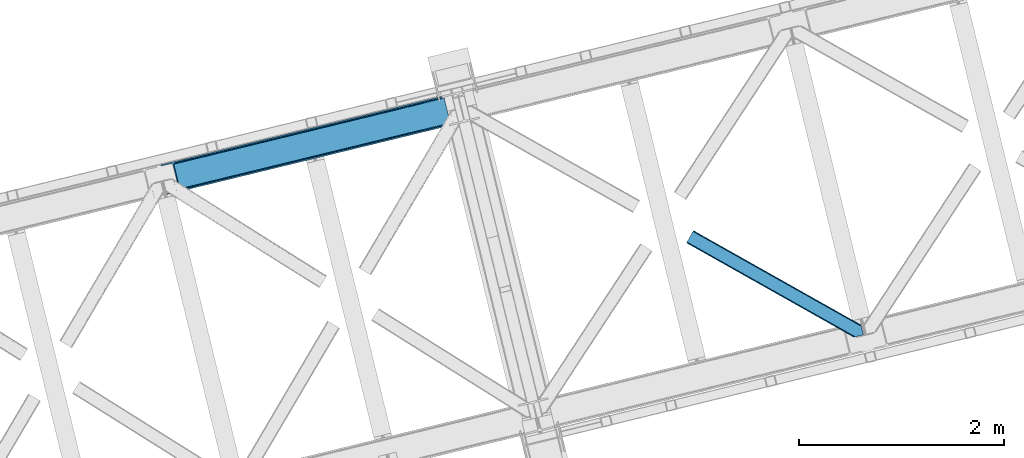
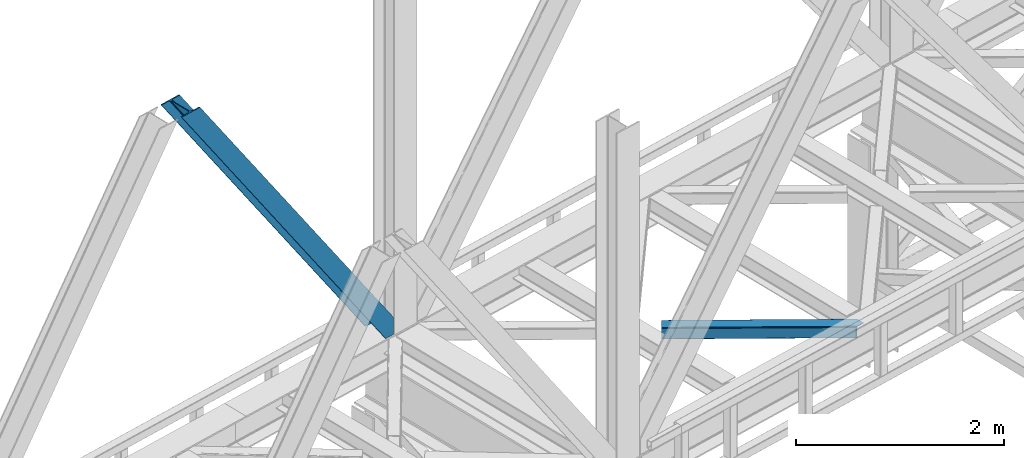
# One storey, part 38 of 93: 2 members.
"""IFC4 building model written with IfcOpenShell, lengths in millimetres."""

from ifc_helpers import new_model, entity, si_unit, converted_unit, derived_unit, direction, frame, origin, place, context, subcontext, project, spatial, triangles, type_object, element, save


model = new_model("IFC4")

# Units and contexts
model_context = context("Model", 3, precision=0.01, world=origin(), true_north=direction((6.12303176911189e-17, 1.0)))
plan_context = context("Plan", 3, precision=0.01, world=origin(), true_north=direction((6.12303176911189e-17, 1.0)))
body_context = subcontext(model_context, "Body", "Model", "MODEL_VIEW")
ifc_project = project(units=[si_unit("LENGTHUNIT", "METRE", prefix="MILLI"), si_unit("AREAUNIT", "SQUARE_METRE"), si_unit("VOLUMEUNIT", "CUBIC_METRE"), converted_unit("PLANEANGLEUNIT", "DEGREE", entity("IfcRatioMeasure", 0.0174532925199433), si_unit("PLANEANGLEUNIT", "RADIAN"), dimensions=[0, 0, 0, 0, 0, 0, 0]), si_unit("MASSUNIT", "GRAM", prefix="KILO"), derived_unit("MASSDENSITYUNIT", [(si_unit("MASSUNIT", "GRAM", prefix="KILO"), 1), (si_unit("LENGTHUNIT", "METRE"), -3)]), derived_unit("MOMENTOFINERTIAUNIT", [(si_unit("LENGTHUNIT", "METRE"), 4)]), si_unit("TIMEUNIT", "SECOND"), si_unit("FREQUENCYUNIT", "HERTZ"), si_unit("THERMODYNAMICTEMPERATUREUNIT", "DEGREE_CELSIUS"), derived_unit("THERMALTRANSMITTANCEUNIT", [(si_unit("MASSUNIT", "GRAM", prefix="KILO"), 1), (si_unit("THERMODYNAMICTEMPERATUREUNIT", "KELVIN"), -1), (si_unit("TIMEUNIT", "SECOND"), -3)]), derived_unit("VOLUMETRICFLOWRATEUNIT", [(si_unit("LENGTHUNIT", "METRE"), 3), (si_unit("TIMEUNIT", "SECOND"), -1)]), derived_unit("MASSFLOWRATEUNIT", [(si_unit("MASSUNIT", "GRAM", prefix="KILO"), 1), (si_unit("TIMEUNIT", "SECOND"), -1)]), derived_unit("ROTATIONALFREQUENCYUNIT", [(si_unit("TIMEUNIT", "SECOND"), -1)]), si_unit("ELECTRICCURRENTUNIT", "AMPERE"), si_unit("ELECTRICVOLTAGEUNIT", "VOLT"), si_unit("POWERUNIT", "WATT"), si_unit("FORCEUNIT", "NEWTON", prefix="KILO"), si_unit("ILLUMINANCEUNIT", "LUX"), si_unit("LUMINOUSFLUXUNIT", "LUMEN"), si_unit("LUMINOUSINTENSITYUNIT", "CANDELA"), derived_unit("USERDEFINED", [(si_unit("MASSUNIT", "GRAM", prefix="KILO"), -1), (si_unit("LENGTHUNIT", "METRE"), -2), (si_unit("TIMEUNIT", "SECOND"), 3), (si_unit("LUMINOUSFLUXUNIT", "LUMEN"), 1)]), derived_unit("LINEARVELOCITYUNIT", [(si_unit("LENGTHUNIT", "METRE"), 1), (si_unit("TIMEUNIT", "SECOND"), -1)]), si_unit("PRESSUREUNIT", "PASCAL"), derived_unit("USERDEFINED", [(si_unit("LENGTHUNIT", "METRE"), -2), (si_unit("MASSUNIT", "GRAM", prefix="KILO"), 1), (si_unit("TIMEUNIT", "SECOND"), -2)]), derived_unit("LINEARFORCEUNIT", [(si_unit("MASSUNIT", "GRAM", prefix="KILO"), 1), (si_unit("LENGTHUNIT", "METRE"), 1), (si_unit("TIMEUNIT", "SECOND"), -2), (si_unit("LENGTHUNIT", "METRE"), -1)]), derived_unit("PLANARFORCEUNIT", [(si_unit("MASSUNIT", "GRAM", prefix="KILO"), 1), (si_unit("LENGTHUNIT", "METRE"), 1), (si_unit("TIMEUNIT", "SECOND"), -2), (si_unit("LENGTHUNIT", "METRE"), -2)])], contexts=[model_context, plan_context])

# Site, building, storey
site_placement = place(None, origin())
site = spatial("IfcSite", under=ifc_project, at=site_placement, CompositionType="ELEMENT")
building_placement = place(site_placement, origin())
building = spatial("IfcBuilding", under=site, at=building_placement, CompositionType="ELEMENT")
storey_placement = place(building_placement, frame((0.0, 0.0, 15900.0)))
storey = spatial("IfcBuildingStorey", under=building, at=storey_placement, CompositionType="ELEMENT", Elevation=15900.0)

# Members
member_type_1 = type_object("IfcMemberType", PredefinedType="BRACE")
member_1_placement = place(storey_placement, frame((-52278.8368652344, 7914.03961029053, 3694.99929199219)))
element("IfcMember", 1, at=member_1_placement, inside=storey, type_object=member_type_1, ObjectType="Steel Vertical Brace", PredefinedType="BRACE", context=body_context, shape_type="Tessellation", body=[
    triangles([(2824.17180175782, 696.209248352051, 0.781347656247817), (2824.8368774414, 695.227912902831, 1.0697021484375), (2823.33929443359, 694.862818908691, 0.0), (2821.44638671875, 702.635018920898, 0.0), (2812.38182373047, 692.19088897705, 19.5569458007813), (2812.38182373047, 692.19088897705, 0.0), (2386.756640625, 583.574263000489, 658.75048828125), (2392.34234619141, 580.919773864746, 662.07819213867), (2803.98698730469, 681.26248626709, 51.2480346679658), (2804.11721191406, 683.186787414551, 44.4996093749978), (2382.25924072265, 588.488497924805, 656.525042724606), (2808.48903808594, 690.380534362793, 26.4030395507798), (2805.01948242188, 685.664543151855, 38.2720825195283), (2805.58688964844, 687.218518066406, 34.3676696777329), (630.519653320313, 150.046073913574, 3288.98063964843), (624.696752929689, 150.036772155761, 3285.05529785156), (211.3359375, 47.8656829833981, 3911.00081176758), (202.866687011723, 47.2110717773439, 3911.00081176758), (619.11104736328, 152.691842651367, 3281.72759399414), (195.039257812503, 49.3190826416012, 3911.00081176758), (614.613647460938, 157.60549621582, 3279.50447387695), (189.03962402344, 53.868223571777, 3911.00081176758), (611.888232421879, 164.031266784667, 3278.7231262207), (185.788659667967, 60.1655136108393, 3911.00081176758), (2804.10791015625, 679.881175231933, 63.6403015136711), (2398.16524658203, 580.929075622559, 666.003533935545), (1956.25733642578, 473.208325195313, 1321.74955444336), (1950.42978515625, 473.1990234375, 1317.82188720703), (1508.521875, 365.478273010253, 1973.56790771484), (1514.34477539063, 365.487574768066, 1977.49324951172), (1066.60931396484, 257.757522583008, 2629.3116027832), (1072.43221435547, 257.76682434082, 2633.23694458008), (1944.84873046875, 475.854093933106, 1314.49418334961), (1502.93151855469, 368.132762145996, 1970.23787841797), (1061.02360839844, 260.412011718749, 2625.98389892578), (1940.3466796875, 480.767747497558, 1312.27106323242), (1498.43411865235, 373.046997070312, 1968.01475830078), (1056.52620849609, 265.326246643066, 2623.75845336914), (2379.5338256836, 594.914268493651, 655.74602050781), (1937.62126464844, 487.193518066407, 1311.48971557617), (1495.71335449219, 379.47276763916, 1967.23341064453), (1053.80079345703, 271.752017211914, 2622.97710571289), (2766.268359375, 929.006666564942, 0.0), (2324.35579833984, 821.285916137695, 655.74602050781), (1882.44323730469, 713.565165710449, 1311.48971557617), (1440.53067626953, 605.844415283203, 1967.23341064453), (998.618115234378, 498.123664855956, 2622.97710571289), (556.705554199223, 390.402914428711, 3278.7231262207), (130.61063232422, 286.537161254883, 3911.00081176758), (303.26520996094, 70.2747802734375, 3911.00081176758), (2804.10791015625, 679.881175231933, 200.055230712889), (2807.14028320312, 667.240086364746, 200.120343017577), (2804.29859619141, 678.898677062988, 200.120343017577), (306.344091796876, 57.6447372436523, 3911.00081176758), (2807.14028320312, 667.240086364746, 0.0), (2804.29859619141, 678.898677062988, 0.0), (2804.0009399414, 682.093249511719, 0.0), (2804.11721191406, 683.186787414551, 2.42078247070094), (2804.72182617187, 685.456997680664, 5.12991943359157), (2805.58688964844, 687.218518066406, 5.67639770507594), (2807.01936035157, 689.087008666992, 4.89505004882813), (2808.48903808594, 690.380534362793, 3.35328369140552), (2811.04237060547, 691.772309875488, 0.0), (2705.52322998047, 642.470086669921, 0.0), (69.865502929686, 0.0, 3911.00081176758), (2794.37827148438, 677.509226989746, 0.0), (2802.00106201172, 681.140400695801, 0.0), (2702.44434814453, 655.100129699706, 0.0), (66.78662109375, 12.6306243896479, 3911.00081176758), (1480.00268554688, 357.117155456544, 1950.37164916992), (1034.29035644532, 248.469717407226, 2611.75686035156), (588.578027343749, 139.82227935791, 3273.1420715332), (158.720544433592, 35.0397216796873, 3911.00081176758), (1925.71966552734, 465.76459350586, 1288.98643798828), (2371.43199462891, 574.412031555176, 627.598901367186), (2376.60842285156, 577.083380126954, 631.526568603513), (2380.34307861328, 582.010986328124, 634.854272460936), (2381.53835449219, 595.402610778808, 637.858740234373), (2811.39583740234, 700.185168457031, 0.0), (2811.09818115235, 693.083857727051, 0.0), (2382.07785644531, 588.443733215331, 637.077392578125), (598.684387207031, 160.812858581543, 3283.40191040039), (599.21923828125, 153.853981018066, 3282.62056274414), (175.738110351565, 57.7156631469725, 3911.00081176758), (175.752062988286, 50.6283050537104, 3911.00081176758), (597.489111328126, 147.421234130859, 3280.39744262695), (172.519702148442, 43.8304641723635, 3911.00081176758), (593.749804687504, 142.493627929687, 3277.06973876953), (166.538671875001, 38.3563796997068, 3911.00081176758), (1936.36087646485, 479.796295166015, 1298.46260375976), (1935.82602539063, 486.755172729491, 1299.24395141601), (1490.64854736329, 371.148857116698, 1959.85014038086), (1490.10904541016, 378.107734680175, 1960.63148803711), (1044.3967163086, 269.460296630859, 2622.01669921875), (1044.93621826172, 262.501419067383, 2621.2353515625), (1934.63074951172, 473.363548278808, 1296.23948364258), (1488.91376953125, 364.716110229491, 1957.62469482422), (1043.20144042969, 256.068672180176, 2619.01223144531), (1930.89144287109, 468.435942077637, 1292.91177978515), (1485.17911376953, 359.788504028321, 1954.2969909668), (1039.46678466797, 251.141065979004, 2615.68220214844), (2756.2178100586, 926.556816101073, 0.0), (2326.36032714844, 821.774258422852, 637.858740234373), (1434.93101806641, 604.479382324219, 1960.63148803711), (1880.64334716797, 713.126820373535, 1299.24395141601), (989.214038085942, 495.831944274903, 2622.01669921875), (543.501708984375, 387.184506225586, 3283.40191040039), (120.560083007811, 284.087310791015, 3911.00081176758), (2752.68314208985, 932.723881530762, 0.0), (2753.40867919922, 934.106936645508, 0.0), (2752.03201904297, 933.86276550293, 0.0), (2764.37080078125, 936.778866577149, 0.0), (2753.40867919922, 934.106936645508, 19.5569458007813), (2765.86838378906, 937.143960571289, 1.0697021484375), (2765.72885742188, 935.96612548828, 0.781347656247817), (2325.55107421875, 834.677540588379, 658.75048828125), (2749.12521972656, 933.923808288574, 26.4030395507798), (2745.08825683594, 935.395230102539, 34.3676696777329), (2323.81629638672, 828.244793701172, 656.525042724606), (2743.51160888672, 936.560275268555, 38.5441589355469), (556.170703125004, 397.36237335205, 3279.50447387695), (130.5966796875, 293.624519348144, 3911.00081176758), (557.900830078128, 403.794538879395, 3281.72759399414), (133.829040527344, 300.422360229492, 3911.00081176758), (561.64013671875, 408.722145080566, 3285.05529785156), (139.810070800784, 305.896444702149, 3911.00081176758), (566.811914062499, 411.393493652343, 3288.98063964843), (147.628198242186, 309.213102722169, 3911.00081176758), (2740.93037109375, 939.947277832031, 51.2480346679658), (2740.40017089844, 941.228594970703, 63.6403015136711), (2329.28572998047, 839.605146789551, 662.07819213867), (2334.46215820313, 842.276495361329, 666.003533935545), (2742.09309082032, 938.421789550782, 45.5251281738274), (1881.90373535157, 720.524043273926, 1312.27106323242), (1439.9911743164, 612.803874206543, 1968.01475830078), (998.083264160159, 505.083123779296, 2623.75845336914), (1883.63851318359, 726.956790161133, 1314.49418334961), (1441.72595214844, 619.236039733886, 1970.23787841797), (999.813391113283, 511.51528930664, 2625.98389892578), (1887.37316894531, 731.883815002441, 1317.82188720703), (1445.46060791016, 624.163064575195, 1973.56790771484), (1003.5526977539, 516.442895507812, 2629.3116027832), (1892.54959716797, 734.555744934082, 1321.74955444336), (1450.63703613282, 626.834994506836, 1977.49324951172), (1008.72447509766, 519.114244079589, 2633.23694458008), (2740.40017089844, 941.228594970703, 200.055230712889), (239.562121582036, 331.622200012206, 3911.00081176758), (2749.12521972656, 933.923808288574, 3.35328369140552), (2745.08825683594, 935.395230102539, 5.67639770507594), (2747.22766113281, 934.392965698243, 4.89272460937354), (2743.51160888672, 936.560275268555, 5.12991943359157), (2740.12111816406, 942.189001464844, 0.0), (2741.9303100586, 938.297959899902, 2.42078247070094), (2740.12111816406, 942.189001464844, 200.120343017577), (2741.32569580078, 939.216508483886, 0.0), (2323.63026123047, 828.200028991699, 637.077392578125), (2319.13286132813, 833.114263916016, 634.854272460936), (2313.54715576172, 835.768753051757, 631.526568603513), (2307.7242553711, 835.759451293946, 627.598901367186), (2730.67053222656, 938.856646728515, 0.0), (2739.11187744141, 939.141513061523, 0.0), (524.870288085942, 401.16969909668, 3273.1420715332), (530.693188476565, 401.179000854491, 3277.06973876953), (103.482055664063, 297.041171264648, 3911.00081176758), (95.0128051757856, 296.387141418457, 3911.00081176758), (536.278894042967, 398.524511718751, 3280.39744262695), (111.309484863283, 294.933741760254, 3911.00081176758), (540.776293945317, 393.610276794433, 3282.62056274414), (117.309118652345, 290.384600830078, 3911.00081176758), (1862.01192626953, 727.112013244629, 1288.98643798828), (1867.83482666016, 727.121315002441, 1292.91177978515), (1416.29959716797, 618.464575195313, 1950.37164916992), (1422.12249755859, 618.473876953124, 1954.2969909668), (976.405517578125, 509.826438903808, 2615.68220214844), (970.582617187501, 509.817137145997, 2611.75686035156), (1873.42053222656, 724.4668258667, 1296.23948364258), (1427.708203125, 615.819387817383, 1957.62469482422), (981.995874023436, 507.171949768067, 2619.01223144531), (1877.9179321289, 719.552590942382, 1298.46260375976), (1432.20560302735, 610.905152893066, 1959.85014038086), (986.493273925786, 502.257714843749, 2621.2353515625), (2737.27943115235, 953.84817352295, 200.120343017577), (236.483239746092, 344.252824401855, 3911.00081176758), (2737.27943115235, 953.84817352295, 0.0), (0.0, 286.608087158203, 3911.00081176758), (3.07888183593604, 273.978044128417, 3911.00081176758), (2635.66237792969, 929.077592468261, 0.0), (2638.74125976563, 916.447549438476, 0.0)], [[1, 2, 3], [3, 4, 1], [2, 5, 6], [6, 3, 2], [7, 8, 9], [9, 10, 7], [11, 12, 5], [5, 1, 11], [5, 2, 1], [11, 7, 13], [13, 14, 11], [14, 12, 11], [15, 16, 17], [18, 17, 16], [16, 19, 18], [20, 18, 19], [19, 21, 20], [22, 20, 21], [21, 23, 22], [24, 22, 23], [10, 13, 7], [25, 9, 8], [8, 26, 25], [26, 8, 27], [28, 27, 8], [27, 28, 29], [29, 30, 27], [30, 29, 31], [31, 32, 30], [32, 31, 15], [16, 15, 31], [8, 7, 33], [33, 28, 8], [28, 33, 29], [34, 29, 33], [29, 34, 31], [35, 31, 34], [31, 35, 16], [19, 16, 35], [7, 11, 36], [36, 33, 7], [33, 36, 37], [37, 34, 33], [34, 37, 35], [38, 35, 37], [35, 38, 21], [21, 19, 35], [1, 4, 11], [39, 11, 4], [11, 39, 36], [40, 36, 39], [36, 40, 37], [41, 37, 40], [37, 41, 42], [42, 38, 37], [38, 42, 21], [23, 21, 42], [4, 43, 44], [45, 39, 44], [41, 40, 45], [41, 45, 46], [44, 39, 4], [45, 40, 39], [42, 41, 46], [46, 47, 42], [47, 48, 23], [49, 24, 48], [47, 23, 42], [48, 24, 23], [50, 51, 30], [30, 32, 50], [32, 15, 50], [17, 50, 15], [27, 30, 51], [51, 25, 26], [26, 27, 51], [52, 53, 54], [53, 51, 50], [50, 54, 53], [52, 55, 53], [56, 53, 55], [56, 9, 25], [56, 57, 58], [58, 10, 56], [10, 9, 56], [59, 60, 14], [14, 13, 59], [10, 58, 59], [60, 61, 12], [12, 14, 60], [5, 62, 63], [63, 6, 5], [5, 12, 62], [61, 62, 12], [13, 10, 59], [25, 51, 53], [53, 56, 25], [54, 64, 52], [54, 65, 64], [64, 55, 52], [56, 66, 67], [55, 66, 56], [67, 57, 56], [64, 66, 55], [64, 68, 66], [68, 64, 69], [65, 69, 64], [69, 70, 68], [71, 69, 72], [69, 71, 70], [69, 73, 72], [74, 68, 70], [66, 68, 75], [74, 75, 68], [67, 76, 58], [76, 77, 59], [59, 58, 76], [76, 67, 66], [78, 79, 80], [81, 60, 59], [81, 80, 62], [62, 61, 81], [61, 60, 81], [80, 63, 62], [59, 77, 81], [80, 81, 78], [82, 83, 84], [85, 84, 83], [83, 86, 85], [87, 85, 86], [86, 88, 87], [89, 87, 88], [88, 72, 89], [73, 89, 72], [66, 75, 76], [58, 57, 67], [78, 81, 90], [90, 91, 78], [91, 90, 92], [92, 93, 91], [93, 92, 94], [95, 94, 92], [94, 95, 83], [83, 82, 94], [81, 77, 90], [96, 90, 77], [90, 96, 92], [97, 92, 96], [92, 97, 95], [98, 95, 97], [95, 98, 83], [86, 83, 98], [77, 76, 96], [99, 96, 76], [96, 99, 100], [100, 97, 96], [97, 100, 101], [101, 98, 97], [98, 101, 88], [88, 86, 98], [76, 75, 74], [74, 99, 76], [99, 74, 70], [70, 100, 99], [100, 70, 101], [71, 101, 70], [101, 71, 72], [72, 88, 101], [102, 79, 78], [91, 103, 78], [104, 105, 91], [104, 91, 93], [78, 103, 102], [91, 105, 103], [106, 104, 93], [93, 94, 106], [94, 82, 107], [84, 108, 82], [94, 107, 106], [82, 108, 107], [109, 102, 110], [6, 79, 80], [6, 80, 63], [110, 111, 109], [3, 79, 6], [79, 4, 102], [3, 4, 79], [43, 102, 4], [102, 112, 110], [112, 102, 43], [113, 114, 110], [112, 110, 114], [114, 115, 112], [43, 112, 115], [116, 117, 118], [119, 115, 113], [113, 116, 119], [113, 117, 116], [115, 114, 113], [118, 120, 116], [48, 121, 122], [122, 49, 48], [121, 123, 124], [124, 122, 121], [123, 125, 126], [126, 124, 123], [125, 127, 128], [128, 126, 125], [129, 130, 131], [132, 131, 130], [133, 116, 120], [116, 133, 129], [131, 116, 129], [43, 115, 119], [119, 44, 43], [44, 119, 134], [134, 45, 44], [45, 134, 46], [135, 46, 134], [46, 135, 47], [136, 47, 135], [47, 136, 121], [121, 48, 47], [119, 116, 134], [137, 134, 116], [134, 137, 135], [138, 135, 137], [135, 138, 139], [139, 136, 135], [136, 139, 123], [123, 121, 136], [116, 131, 140], [140, 137, 116], [137, 140, 141], [141, 138, 137], [138, 141, 142], [142, 139, 138], [139, 142, 123], [125, 123, 142], [131, 132, 143], [143, 140, 131], [140, 143, 141], [144, 141, 143], [141, 144, 142], [145, 142, 144], [142, 145, 127], [127, 125, 142], [144, 146, 147], [147, 127, 145], [127, 147, 128], [145, 144, 147], [146, 144, 143], [143, 132, 146], [130, 146, 132], [113, 110, 111], [148, 117, 113], [149, 118, 117], [117, 148, 150], [151, 133, 120], [118, 149, 151], [151, 120, 118], [152, 133, 153], [152, 129, 133], [146, 130, 154], [152, 154, 130], [130, 129, 152], [153, 155, 152], [151, 153, 133], [117, 150, 149], [111, 148, 113], [156, 150, 148], [156, 149, 150], [148, 109, 156], [148, 111, 109], [156, 157, 151], [151, 149, 156], [103, 156, 109], [158, 159, 160], [158, 153, 151], [158, 161, 153], [161, 155, 153], [151, 157, 158], [160, 161, 158], [162, 163, 164], [164, 165, 162], [163, 166, 167], [167, 164, 163], [166, 168, 169], [169, 167, 166], [168, 107, 108], [108, 169, 168], [109, 102, 103], [159, 158, 170], [171, 170, 158], [170, 171, 172], [173, 172, 171], [172, 173, 174], [174, 175, 172], [175, 174, 162], [163, 162, 174], [158, 157, 176], [176, 171, 158], [171, 176, 173], [177, 173, 176], [173, 177, 174], [178, 174, 177], [174, 178, 163], [166, 163, 178], [157, 156, 179], [179, 176, 157], [176, 179, 180], [180, 177, 176], [177, 180, 181], [181, 178, 177], [178, 181, 168], [168, 166, 178], [156, 103, 179], [105, 179, 103], [179, 105, 180], [104, 180, 105], [180, 104, 106], [106, 181, 180], [181, 106, 168], [107, 168, 106], [146, 154, 147], [154, 182, 183], [183, 147, 154], [154, 152, 184], [184, 182, 154], [108, 84, 49], [87, 89, 18], [73, 65, 54], [69, 65, 73], [89, 73, 17], [84, 85, 22], [85, 87, 20], [167, 126, 164], [185, 165, 183], [165, 164, 128], [185, 186, 165], [167, 169, 124], [169, 108, 122], [49, 84, 24], [17, 18, 89], [22, 85, 20], [18, 20, 87], [22, 24, 84], [54, 17, 73], [54, 50, 17], [128, 164, 126], [124, 169, 122], [49, 122, 108], [124, 126, 167], [128, 183, 165], [183, 128, 147], [152, 160, 184], [155, 161, 152], [152, 161, 160], [160, 187, 184], [187, 160, 188], [183, 187, 185], [187, 183, 182], [184, 187, 182], [172, 186, 188], [162, 186, 175], [162, 165, 186], [172, 175, 186], [188, 170, 172], [159, 170, 188], [188, 160, 159], [187, 188, 185], [186, 185, 188]]),
])
member_type_2 = type_object("IfcMemberType", PredefinedType="BRACE")
member_2_placement = place(storey_placement, frame((-47153.9868896484, 6520.94441070557, 3511.0000579834)))
element("IfcMember", 2, at=member_2_placement, inside=storey, type_object=member_type_2, ObjectType="Steel Horizontal Brace", PredefinedType="BRACE", context=body_context, shape_type="Tessellation", body=[
    triangles([(1645.8158203125, 3.74512023925763, 138.667117309571), (1655.3408203125, 6.06707153320258, 139.999594116212), (8.58552246094041, 933.436047363281, 139.999594116212), (5.302001953125, 927.600938415527, 138.667117309571), (1637.74189453125, 1.7772171020506, 134.874325561526), (2.51612548828416, 922.654147338867, 134.874325561526), (1632.346875, 0.462181091308594, 129.197927856447), (0.651123046875, 919.348535156249, 129.197927856447), (1630.44931640625, 0.0, 122.500662231447), (0.0, 918.188140869141, 122.500662231447), (1630.44931640625, 0.0, 17.5000946044929), (0.0, 918.188140869141, 17.5000946044929), (1706.57025146484, 97.721360778808, 139.999594116212), (1724.78774414062, 22.9951080322262, 139.999594116212), (60.1079589843794, 1024.92639312744, 139.999594116212), (1701.3287109375, 119.229350280762, 129.197927856447), (1700.89617919922, 121.001335144043, 122.500662231447), (68.0423583984375, 1039.01390533447, 129.197927856447), (68.6981323242217, 1040.17429962158, 122.500662231447), (1702.55654296875, 114.182565307617, 134.874325561526), (66.1820068359375, 1035.70829315186, 134.874325561526), (1704.39829101563, 106.63011932373, 138.667117309571), (63.3961303710967, 1030.7615020752, 138.667117309571), (1700.89617919922, 121.001335144043, 17.5000946044929), (68.6981323242217, 1040.17429962158, 17.5000946044929), (0.651123046875, 919.348535156249, 10.8028289794929), (1633.02590332031, 0.628450012206486, 10.9377044677749), (2.51612548828416, 922.654147338867, 5.12526855468968), (5.302001953125, 927.600938415527, 1.33247680664135), (1569.79720458984, 46.5547164916989, 1.33247680664135), (1573.68999023438, 34.8100845336912, 8.52041015625218), (1571.51337890625, 39.517936706543, 5.59500732422021), (1572.2900756836, 36.3402236938473, 7.52047119140843), (1573.35047607422, 35.1804107666012, 8.278564453125), (1572.98770751953, 35.5751541137688, 8.02044067383031), (1572.62493896484, 35.9693161010737, 7.76231689453198), (1633.97468261719, 0.859831237792605, 8.52041015625218), (1567.62524414063, 55.4634750366204, 0.0), (8.58552246094041, 933.436047363281, 0.0), (1533.57615966797, 195.142739868164, 0.0), (60.1079589843794, 1024.92639312744, 0.0), (1566.72762451172, 59.1411575317379, 7.52047119140843), (1567.24387207031, 57.3430114746088, 7.90300598144677), (1567.78337402344, 56.4360900878901, 8.1076446533225), (1568.32752685547, 55.5204483032221, 8.31460876464917), (1568.41124267579, 55.3762710571282, 8.3471649169951), (1568.86237792969, 54.6129455566406, 8.52041015625218), (1655.15013427735, 6.02056274414008, 8.52041015625218), (5.94847412109812, 928.753193664551, 12.1260040283232), (1647.69477539063, 4.20381317138617, 12.1260040283232), (8.73435058593896, 933.700566101074, 8.3320495605476), (12.0225219726563, 939.535675048828, 6.99957275390625), (1565.35561523437, 64.7751159667969, 6.99957275390625), (1642.29975585938, 2.88877716064417, 17.8035644531265), (4.08812255859812, 925.448162841797, 17.8035644531265), (1640.40684814454, 2.42717742919922, 24.4996673583992), (3.43234863281396, 924.287187194824, 24.4996673583992), (1640.40684814454, 2.42717742919922, 115.501089477541), (3.43234863281396, 924.287187194824, 115.501089477541), (1647.69477539063, 4.20381317138617, 127.87475280762), (1655.77335205078, 6.17229766845685, 131.667544555665), (1642.29975585938, 2.88877716064417, 122.196029663086), (1665.29835205078, 8.4942489624018, 133.000021362306), (1724.78774414062, 22.9951080322262, 133.000021362306), (4.08812255859812, 925.448162841797, 122.196029663086), (5.94847412109812, 928.753193664551, 127.87475280762), (8.73435058593896, 933.700566101074, 131.667544555665), (12.0225219726563, 939.535675048828, 133.000021362306), (1708.8398803711, 88.4097198486324, 133.000021362306), (56.6756103515654, 1018.82676544189, 133.000021362306), (1535.84578857422, 185.831098937988, 6.99957275390625), (56.6756103515654, 1018.82676544189, 6.99957275390625), (68.0423583984375, 1039.01390533447, 10.8028289794929), (62.7450073242217, 1029.60924682617, 12.1260040283232), (64.6100097656235, 1032.91427764893, 17.8035644531265), (65.2611328124985, 1034.0752532959, 24.4996673583992), (66.1820068359375, 1035.70829315186, 5.12526855468968), (63.3961303710967, 1030.7615020752, 1.33247680664135), (59.9591308593735, 1024.66187438965, 8.3320495605476), (62.7450073242217, 1029.60924682617, 127.87475280762), (65.2611328124985, 1034.0752532959, 115.501089477541), (64.6100097656235, 1032.91427764893, 122.196029663086), (59.9591308593735, 1024.66187438965, 131.667544555665), (1703.16580810547, 111.689694213866, 24.4996673583992), (1703.16580810547, 111.689694213866, 115.501089477541), (1706.66791992188, 97.318478393554, 131.667544555665), (1704.826171875, 104.870924377441, 127.87475280762), (1703.59833984375, 109.917127990722, 122.196029663086), (1704.826171875, 104.870924377441, 12.1260040283232), (1706.52839355469, 97.8998382568352, 8.52041015625218), (1701.70078125, 117.702699279785, 8.52041015625218), (1703.59833984375, 109.917127990722, 17.8035644531265), (1701.48218994141, 118.590435791015, 10.9365417480476), (1534.47377929687, 191.465057373047, 7.52047119140843), (1529.69267578125, 211.088278198242, 5.59500732422021), (1528.9159790039, 214.265991210938, 7.52047119140843), (1531.40419921875, 204.051498413086, 1.33247680664135), (1529.11596679688, 214.689221191406, 8.22740478515698), (1529.01364746094, 214.477606201172, 7.87393798828271), (1529.90196533204, 214.452026367188, 8.52041015625218), (1534.34820556641, 192.705679321289, 7.85649719238427), (1534.72957763672, 194.649165344238, 8.52041015625218)], [[1, 2, 3], [3, 4, 1], [5, 1, 4], [4, 6, 5], [7, 5, 6], [6, 8, 7], [9, 7, 8], [8, 10, 9], [11, 9, 12], [10, 12, 9], [2, 13, 3], [2, 14, 13], [15, 3, 13], [16, 17, 18], [19, 18, 17], [20, 16, 21], [18, 21, 16], [22, 20, 23], [21, 23, 20], [13, 22, 15], [23, 15, 22], [17, 24, 19], [25, 19, 24], [26, 27, 11], [28, 29, 30], [27, 26, 31], [26, 28, 32], [32, 33, 26], [34, 26, 35], [34, 31, 26], [26, 36, 35], [26, 33, 36], [31, 37, 27], [30, 32, 28], [38, 30, 29], [29, 39, 38], [11, 12, 26], [40, 38, 39], [39, 41, 40], [33, 42, 43], [36, 43, 44], [35, 44, 45], [34, 46, 47], [34, 45, 46], [47, 31, 34], [45, 34, 35], [44, 35, 36], [43, 36, 33], [48, 37, 47], [31, 47, 37], [49, 50, 47], [47, 51, 49], [47, 46, 51], [50, 48, 47], [52, 43, 42], [51, 46, 45], [45, 52, 51], [45, 44, 52], [43, 52, 44], [42, 53, 52], [54, 50, 49], [49, 55, 54], [56, 54, 55], [55, 57, 56], [58, 56, 59], [57, 59, 56], [60, 61, 1], [5, 60, 1], [5, 7, 62], [60, 5, 62], [62, 7, 9], [61, 2, 1], [14, 63, 64], [14, 2, 63], [61, 63, 2], [62, 9, 58], [56, 11, 54], [9, 56, 58], [11, 27, 54], [9, 11, 56], [37, 54, 27], [50, 54, 37], [48, 50, 37], [62, 58, 65], [59, 65, 58], [60, 62, 66], [65, 66, 62], [61, 60, 67], [66, 67, 60], [63, 61, 68], [67, 68, 61], [69, 63, 68], [63, 69, 64], [68, 70, 69], [53, 71, 52], [72, 52, 71], [73, 74, 75], [76, 19, 25], [73, 75, 25], [73, 77, 74], [75, 76, 25], [74, 77, 78], [72, 41, 39], [41, 79, 78], [79, 41, 72], [79, 74, 78], [18, 80, 21], [81, 19, 76], [19, 82, 18], [82, 19, 81], [18, 82, 80], [15, 70, 3], [23, 21, 80], [80, 83, 23], [83, 70, 15], [15, 23, 83], [49, 29, 28], [39, 52, 72], [39, 51, 52], [51, 39, 29], [49, 51, 29], [57, 12, 10], [26, 55, 49], [28, 26, 49], [55, 26, 12], [57, 55, 12], [4, 66, 6], [3, 70, 68], [68, 67, 3], [67, 66, 4], [4, 3, 67], [8, 6, 66], [10, 59, 57], [65, 10, 8], [10, 65, 59], [65, 8, 66], [84, 85, 81], [81, 76, 84], [86, 69, 70], [70, 83, 86], [87, 86, 83], [83, 80, 87], [88, 87, 80], [80, 82, 88], [85, 88, 82], [82, 81, 85], [87, 20, 22], [89, 90, 91], [20, 87, 88], [86, 87, 22], [86, 13, 69], [14, 69, 13], [69, 14, 64], [86, 22, 13], [24, 17, 84], [91, 92, 89], [92, 24, 84], [93, 92, 91], [93, 24, 92], [17, 85, 84], [88, 16, 20], [17, 16, 88], [85, 17, 88], [40, 71, 53], [94, 95, 96], [40, 94, 71], [94, 97, 95], [94, 40, 97], [38, 40, 53], [42, 38, 53], [32, 42, 33], [42, 30, 38], [42, 32, 30], [73, 25, 24], [98, 99, 77], [96, 77, 99], [96, 95, 77], [73, 93, 100], [100, 77, 73], [100, 98, 77], [93, 91, 100], [78, 77, 95], [97, 40, 41], [41, 78, 97], [95, 97, 78], [24, 93, 73], [72, 71, 94], [94, 79, 72], [101, 102, 79], [79, 94, 101], [74, 79, 102], [90, 89, 102], [74, 102, 89], [92, 84, 75], [76, 75, 84], [89, 92, 74], [75, 74, 92], [101, 94, 99], [102, 101, 99], [91, 90, 102], [102, 100, 91]]),
])

save(model, "model.ifc")
